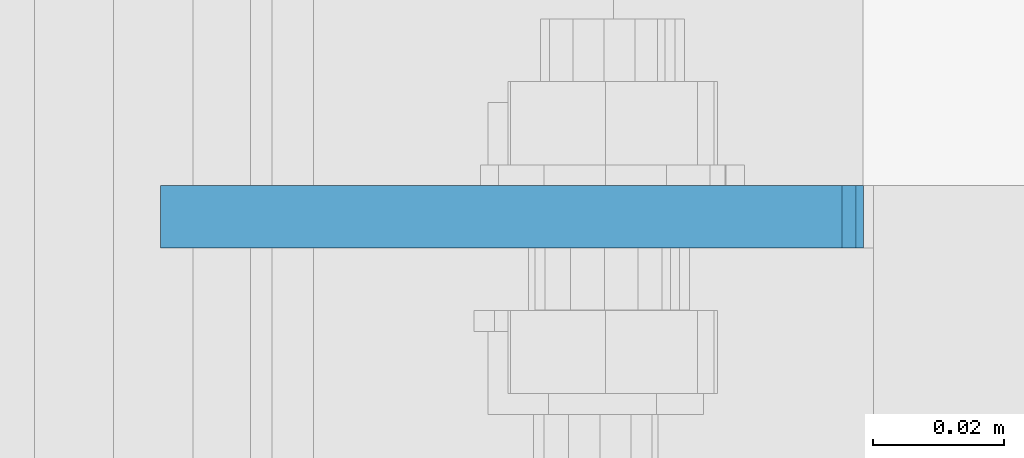
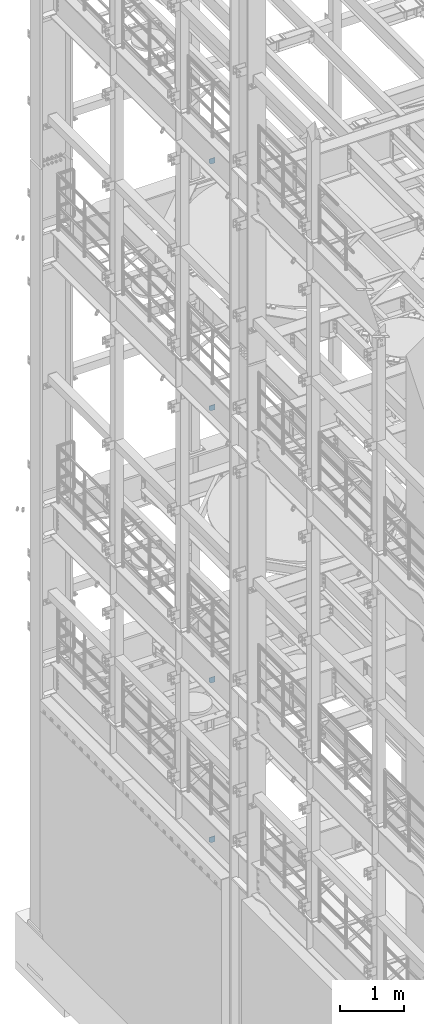
# One storey, part 1705 of 1876: 4 plates, 4 elements without a shape of their own.
"""IFC2X3 building model written with IfcOpenShell, lengths in millimetres."""

from ifc_helpers import new_model, si_unit, frame, origin_with_axes, place, context, subcontext, project, spatial, faceted_brep, material, type_object, element, aggregate, save


model = new_model("IFC2X3")

# Units and contexts
model_context = context("Model", 3, precision=1e-05, world=origin_with_axes())
body_context = subcontext(model_context, "Body", "Model", "MODEL_VIEW")
ifc_project = project(units=[si_unit("LENGTHUNIT", "METRE", prefix="MILLI"), si_unit("AREAUNIT", "SQUARE_METRE"), si_unit("VOLUMEUNIT", "CUBIC_METRE"), si_unit("MASSUNIT", "GRAM", prefix="KILO"), si_unit("TIMEUNIT", "SECOND"), si_unit("PLANEANGLEUNIT", "RADIAN"), si_unit("SOLIDANGLEUNIT", "STERADIAN"), si_unit("THERMODYNAMICTEMPERATUREUNIT", "DEGREE_CELSIUS"), si_unit("LUMINOUSINTENSITYUNIT", "LUMEN")], contexts=[model_context])

# Site, building, storey
site_placement = place(None, origin_with_axes())
site = spatial("IfcSite", under=ifc_project, at=site_placement, CompositionType="ELEMENT")
building_placement = place(site_placement, origin_with_axes())
building = spatial("IfcBuilding", under=site, at=building_placement, Name="Undefined", CompositionType="ELEMENT")
storey_placement = place(building_placement, origin_with_axes())
storey = spatial("IfcBuildingStorey", under=building, at=storey_placement, Name="Undefined", CompositionType="ELEMENT", Elevation=0.0)

# Assembly, plate
assembly_1_placement = place(storey_placement, origin_with_axes())
assembly_1 = element("IfcElementAssembly", 1, at=assembly_1_placement, inside=storey, Name="BEAM", AssemblyPlace="NOTDEFINED", PredefinedType="RIGID_FRAME")
ifc_material = material(Name="STEEL/A36")
plate_type_1 = type_object("IfcPlateType", PredefinedType="NOTDEFINED")
plate_1_placement = place(assembly_1_placement, frame((114.355426115311, 8834.4375, 17386.3), z_axis=(-1.0, 0.0, 0.0), x_axis=(0.0, 0.0, 1.0)))
plate_1 = element("IfcPlate", 2, at=plate_1_placement, type_object=plate_type_1, material=ifc_material, Name="PLATE", context=body_context, shape_type="Brep", body=[
    faceted_brep([(0.0, -4.76249999999982, 0.0), (0.0, -4.76250000000073, 75.4616775512695), (0.0, 4.76250000000073, 75.4616775512695), (0.0, 4.76249999999982, 0.0), (31.75, -4.76250000000073, 107.21167755127), (31.75, 4.76250000000073, 107.21167755127), (102.393173217773, -4.76250000000073, 107.21167755127), (102.393173217773, 4.76250000000073, 107.21167755127), (102.393173217773, -4.76250000000073, 0.0), (102.393173217773, 4.76250000000073, 0.0)], [[[0, 1, 2, 3]], [[1, 4, 5, 2]], [[4, 6, 7, 5]], [[6, 8, 9, 7]], [[8, 0, 3, 9]], [[5, 7, 9, 3, 2]], [[8, 6, 4, 1, 0]]]),
])
aggregate(assembly_1, [plate_1])

assembly_2_placement = place(storey_placement, origin_with_axes())
assembly_2 = element("IfcElementAssembly", 3, at=assembly_2_placement, inside=storey, Name="BEAM", AssemblyPlace="NOTDEFINED", PredefinedType="RIGID_FRAME")
plate_type_2 = type_object("IfcPlateType", PredefinedType="NOTDEFINED")
plate_2_placement = place(assembly_2_placement, frame((7.14375014288484, 8834.43749999999, 12813.2683774958), z_axis=(0.0, 0.0, -1.0), x_axis=(1.0, 0.0, 0.0)))
plate_2 = element("IfcPlate", 4, at=plate_2_placement, type_object=plate_type_2, material=ifc_material, Name="PLATE", context=body_context, shape_type="Brep", body=[
    faceted_brep([(0.0, -4.76249999999982, 0.0), (-3.30797728675947e-06, -4.76250000000073, 68.8183670043927), (-3.30797728675947e-06, 4.76250000000073, 68.8183670043927), (0.0, 4.76249999999982, 0.0), (31.7499961853027, -4.76250000000073, 100.568367004378), (31.7499961853027, 4.76250000000073, 100.568367004378), (103.925315856934, -4.76250000000073, 100.568367004349), (103.925315856934, 4.76250000000073, 100.568367004349), (103.925315856934, -4.76250000000073, -4.54747350886464e-11), (103.925315856934, 4.76250000000073, -4.54747350886464e-11)], [[[0, 1, 2, 3]], [[1, 4, 5, 2]], [[4, 6, 7, 5]], [[6, 8, 9, 7]], [[8, 0, 3, 9]], [[5, 7, 9, 3, 2]], [[8, 6, 4, 1, 0]]]),
])
aggregate(assembly_2, [plate_2])

assembly_3_placement = place(storey_placement, origin_with_axes())
assembly_3 = element("IfcElementAssembly", 5, at=assembly_3_placement, inside=storey, Name="BEAM", AssemblyPlace="NOTDEFINED", PredefinedType="RIGID_FRAME")
plate_type_3 = type_object("IfcPlateType", PredefinedType="NOTDEFINED")
plate_3_placement = place(assembly_3_placement, frame((7.14374999999999, 8834.4375, 7556.5), z_axis=(0.0, 0.0, 1.0), x_axis=(1.0, 0.0, 0.0)))
plate_3 = element("IfcPlate", 6, at=plate_3_placement, type_object=plate_type_3, material=ifc_material, Name="PLATE", context=body_context, shape_type="Brep", body=[
    faceted_brep([(-9.76996261670138e-14, -4.76250000000073, 31.75), (-1.00364161426114e-13, -4.76250000000073, 106.301628112793), (-1.00364161426114e-13, 4.76250000000073, 106.301628112793), (-9.76996261670138e-14, 4.76250000000073, 31.75), (106.018096923828, -4.76250000000073, 106.301628112793), (106.018096923828, 4.76250000000073, 106.301628112793), (106.018096923828, -4.76250000000073, 0.0), (106.018096923828, 4.76250000000073, 0.0), (31.75, -4.76250000000073, 0.0), (31.75, 4.76250000000073, 0.0)], [[[0, 1, 2, 3]], [[1, 4, 5, 2]], [[4, 6, 7, 5]], [[6, 8, 9, 7]], [[8, 0, 3, 9]], [[5, 7, 9, 3, 2]], [[8, 6, 4, 1, 0]]]),
])
aggregate(assembly_3, [plate_3])

assembly_4_placement = place(storey_placement, origin_with_axes())
assembly_4 = element("IfcElementAssembly", 7, at=assembly_4_placement, inside=storey, Name="BEAM", AssemblyPlace="NOTDEFINED", PredefinedType="RIGID_FRAME")
plate_4_placement = place(assembly_4_placement, frame((7.14374999998601, 8834.4375, 4533.89999999999), z_axis=(0.0, 0.0, 1.0), x_axis=(1.0, 0.0, 0.0)))
plate_4 = element("IfcPlate", 8, at=plate_4_placement, type_object=plate_type_3, material=ifc_material, Name="PLATE", context=body_context, shape_type="Brep", body=[
    faceted_brep([(-9.76996261670138e-14, -4.76250000000073, 31.75), (-3.29514193708746e-13, -4.76250000000073, 106.781951904297), (-3.29514193708746e-13, 4.76250000000073, 106.781951904297), (-9.76996261670138e-14, 4.76250000000073, 31.75), (106.131340026855, -4.76250000000073, 106.781951904297), (106.131340026855, 4.76250000000073, 106.781951904297), (106.131340026855, -4.76250000000073, 0.0), (106.131340026855, 4.76250000000073, 0.0), (31.75, -4.76250000000073, 0.0), (31.75, 4.76250000000073, 0.0)], [[[0, 1, 2, 3]], [[1, 4, 5, 2]], [[4, 6, 7, 5]], [[6, 8, 9, 7]], [[8, 0, 3, 9]], [[5, 7, 9, 3, 2]], [[8, 6, 4, 1, 0]]]),
])
aggregate(assembly_4, [plate_4])

save(model, "model.ifc")
